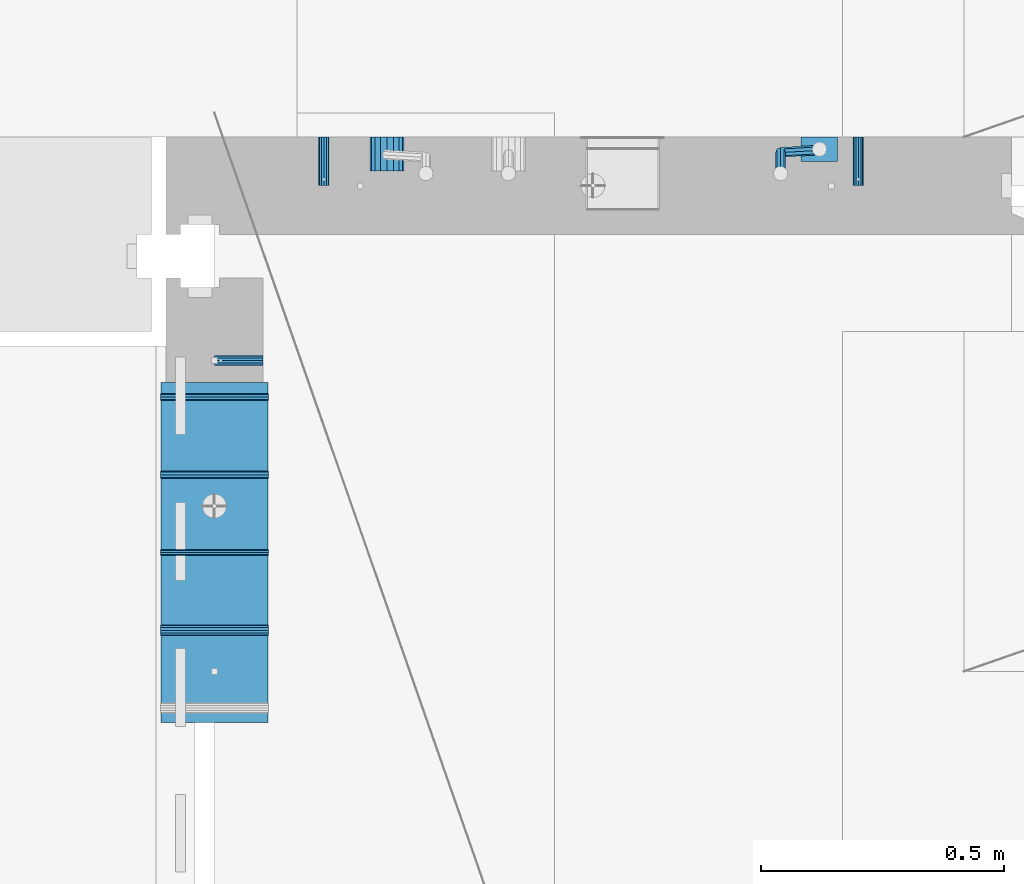
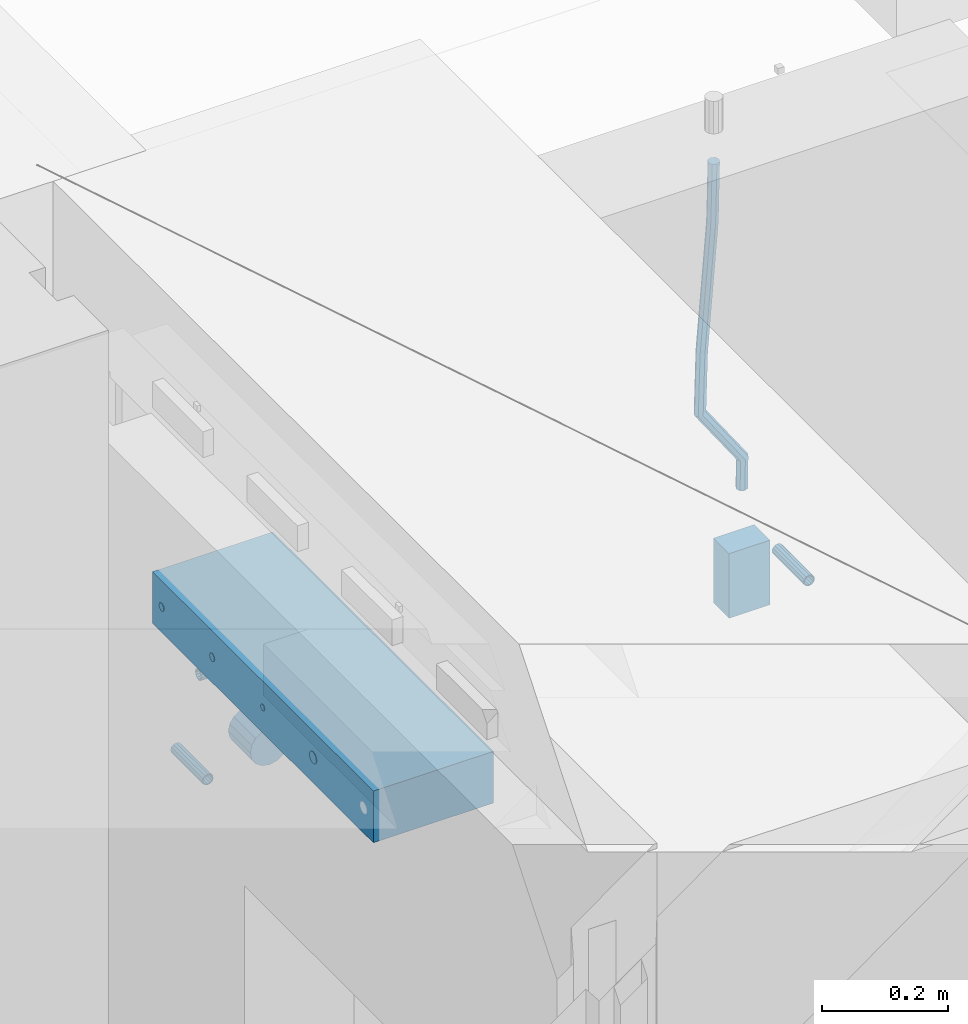
# One storey, part 164 of 349: 11 beams, 5 elements without a shape of their own.
"""IFC2X3 building model written with IfcOpenShell, lengths in millimetres."""

from ifc_helpers import new_model, si_unit, frame, origin_with_axes, place, context, subcontext, project, spatial, faceted_brep, material, type_object, element, aggregate, save


model = new_model("IFC2X3")

# Units and contexts
model_context = context("Model", 3, precision=1e-05, world=origin_with_axes())
body_context = subcontext(model_context, "Body", "Model", "MODEL_VIEW")
ifc_project = project(units=[si_unit("LENGTHUNIT", "METRE", prefix="MILLI"), si_unit("AREAUNIT", "SQUARE_METRE"), si_unit("VOLUMEUNIT", "CUBIC_METRE"), si_unit("MASSUNIT", "GRAM", prefix="KILO"), si_unit("TIMEUNIT", "SECOND"), si_unit("PLANEANGLEUNIT", "RADIAN"), si_unit("SOLIDANGLEUNIT", "STERADIAN"), si_unit("THERMODYNAMICTEMPERATUREUNIT", "DEGREE_CELSIUS"), si_unit("LUMINOUSINTENSITYUNIT", "LUMEN")], contexts=[model_context])

# Site, building, storey
site_placement = place(None, origin_with_axes())
site = spatial("IfcSite", under=ifc_project, at=site_placement, CompositionType="ELEMENT")
building_placement = place(site_placement, origin_with_axes())
building = spatial("IfcBuilding", under=site, at=building_placement, CompositionType="ELEMENT")
storey_placement = place(building_placement, origin_with_axes())
storey = spatial("IfcBuildingStorey", under=building, at=storey_placement, Name="4", CompositionType="ELEMENT", Elevation=0.0)

# Assemblies, beam
assembly_1_placement = place(storey_placement, origin_with_axes())
assembly_1 = element("IfcElementAssembly", 1, at=assembly_1_placement, inside=storey, AssemblyPlace="NOTDEFINED", PredefinedType="REINFORCEMENT_UNIT")
assembly_2_placement = place(assembly_1_placement, origin_with_axes())
assembly_2 = element("IfcElementAssembly", 2, at=assembly_2_placement, Name="Steel Assembly", AssemblyPlace="NOTDEFINED", PredefinedType="RIGID_FRAME")
ifc_material_1 = material(Name="STEEL/Steel_Undefined")
beam_type_1 = type_object("IfcBeamType", PredefinedType="NOTDEFINED")
beam_1_placement = place(assembly_2_placement, frame((26709.9991475894, 16620.0032612672, 93055.0), z_axis=(0.0, 1.0, 0.0), x_axis=(-1.0, 3.00000001838171e-08, 0.0)))
beam_1 = element("IfcBeam", 3, at=beam_1_placement, type_object=beam_type_1, material=ifc_material_1, Name="M16", context=body_context, shape_type="Brep", body=[
    faceted_brep([(0.0, -8.49999999999272, -1.45519152283669e-11), (0.0, -7.36121593215648, 4.24999999998545), (100.000000000262, -7.36121593215648, 4.24999999998545), (100.000000000262, -8.49999999999272, -1.45519152283669e-11), (0.0, -4.24999999998545, 7.36121593216376), (100.000000000262, -4.24999999998545, 7.36121593216376), (0.0, 1.45519152283669e-11, 8.49999999998545), (100.000000000262, 1.45519152283669e-11, 8.49999999998545), (0.0, 4.25000000001455, 7.36121593216376), (100.000000000262, 4.25000000001455, 7.36121593216376), (0.0, 7.36121593217104, 4.24999999998545), (100.000000000262, 7.36121593217104, 4.24999999998545), (0.0, 8.50000000000728, 0.0), (100.000000000262, 8.50000000000728, 0.0), (0.0, 7.36121593217104, -4.25000000001455), (100.000000000262, 7.36121593217104, -4.25000000001455), (0.0, 4.25000000000728, -7.36121593219286), (100.000000000262, 4.25000000000728, -7.36121593219286), (0.0, 7.27595761418343e-12, -8.5), (100.000000000262, 7.27595761418343e-12, -8.5), (0.0, -4.24999999999272, -7.36121593217831), (100.000000000262, -4.24999999999272, -7.36121593217831), (0.0, -7.36121593215648, -4.25), (100.000000000262, -7.36121593215648, -4.25), (0.0, -10.4999999999927, -1.45519152283669e-11), (0.0, -9.09326673972828, -5.25000000001455), (100.000000000262, -9.09326673972828, -5.25000000001455), (100.000000000262, -10.4999999999927, -1.45519152283669e-11), (0.0, -5.24999999998545, -9.09326673974283), (100.000000000262, -5.24999999998545, -9.09326673974283), (0.0, 7.27595761418343e-12, -10.5), (100.000000000262, 7.27595761418343e-12, -10.5), (0.0, 5.25000000001455, -9.09326673975738), (100.000000000262, 5.25000000001455, -9.09326673975738), (0.0, 9.09326673975011, -5.25000000001455), (100.000000000262, 9.09326673975011, -5.25000000001455), (0.0, 10.5000000000073, -1.45519152283669e-11), (100.000000000262, 10.5000000000073, -1.45519152283669e-11), (0.0, 9.09326673975011, 5.25), (100.000000000262, 9.09326673975011, 5.25), (0.0, 5.25000000000728, 9.09326673972828), (100.000000000262, 5.25000000000728, 9.09326673972828), (0.0, 1.45519152283669e-11, 10.4999999999854), (100.000000000262, 1.45519152283669e-11, 10.4999999999854), (0.0, -5.24999999999272, 9.09326673972828), (100.000000000262, -5.24999999999272, 9.09326673972828), (0.0, -9.09326673972828, 5.24999999998545), (100.000000000262, -9.09326673972828, 5.24999999998545)], [[[0, 1, 2, 3]], [[1, 4, 5, 2]], [[4, 6, 7, 5]], [[6, 8, 9, 7]], [[8, 10, 11, 9]], [[10, 12, 13, 11]], [[12, 14, 15, 13]], [[14, 16, 17, 15]], [[16, 18, 19, 17]], [[18, 20, 21, 19]], [[20, 22, 23, 21]], [[22, 0, 3, 23]], [[24, 25, 26, 27]], [[25, 28, 29, 26]], [[28, 30, 31, 29]], [[30, 32, 33, 31]], [[32, 34, 35, 33]], [[34, 36, 37, 35]], [[36, 38, 39, 37]], [[38, 40, 41, 39]], [[40, 42, 43, 41]], [[42, 44, 45, 43]], [[44, 46, 47, 45]], [[46, 24, 27, 47]], [[29, 31, 33, 35, 37, 39, 41, 43, 45, 47, 27, 26], [5, 7, 9, 11, 13, 15, 17, 19, 21, 23, 3, 2]], [[46, 44, 42, 40, 38, 36, 34, 32, 30, 28, 25, 24], [22, 20, 18, 16, 14, 12, 10, 8, 6, 4, 1, 0]]]),
])
aggregate(assembly_2, [beam_1])

# Assemblies, beams
assembly_3_placement = place(storey_placement, origin_with_axes())
assembly_3 = element("IfcElementAssembly", 4, at=assembly_3_placement, inside=storey, AssemblyPlace="NOTDEFINED", PredefinedType="REINFORCEMENT_UNIT")
assembly_4_placement = place(assembly_3_placement, origin_with_axes())
assembly_4 = element("IfcElementAssembly", 5, at=assembly_4_placement, Name="Steel Assembly", AssemblyPlace="NOTDEFINED", PredefinedType="RIGID_FRAME")
beam_2_placement = place(assembly_4_placement, frame((27934.9999668009, 17080.0, 92555.0), z_axis=(1.0, 0.0, 0.0), x_axis=(0.0, -1.0, 0.0)))
beam_2 = element("IfcBeam", 6, at=beam_2_placement, type_object=beam_type_1, material=ifc_material_1, Name="M16", context=body_context, shape_type="Brep", body=[
    faceted_brep([(0.0, -8.49999999999272, -1.45519152283669e-11), (0.0, -7.36121593215648, 4.24999999998545), (100.000000000262, -7.36121593215648, 4.24999999998545), (100.000000000262, -8.49999999999272, -1.45519152283669e-11), (0.0, -4.24999999998545, 7.36121593216376), (100.000000000262, -4.24999999998545, 7.36121593216376), (0.0, 1.45519152283669e-11, 8.49999999998545), (100.000000000262, 1.45519152283669e-11, 8.49999999998545), (0.0, 4.25000000001455, 7.36121593216376), (100.000000000262, 4.25000000001455, 7.36121593216376), (0.0, 7.36121593217104, 4.24999999998545), (100.000000000262, 7.36121593217104, 4.24999999998545), (0.0, 8.50000000000728, 0.0), (100.000000000262, 8.50000000000728, 0.0), (0.0, 7.36121593217104, -4.25000000001455), (100.000000000262, 7.36121593217104, -4.25000000001455), (0.0, 4.25000000000728, -7.36121593219286), (100.000000000262, 4.25000000000728, -7.36121593219286), (0.0, 7.27595761418343e-12, -8.5), (100.000000000262, 7.27595761418343e-12, -8.5), (0.0, -4.24999999999272, -7.36121593217831), (100.000000000262, -4.24999999999272, -7.36121593217831), (0.0, -7.36121593215648, -4.25), (100.000000000262, -7.36121593215648, -4.25), (0.0, -10.4999999999927, -1.45519152283669e-11), (0.0, -9.09326673972828, -5.25000000001455), (100.000000000262, -9.09326673972828, -5.25000000001455), (100.000000000262, -10.4999999999927, -1.45519152283669e-11), (0.0, -5.24999999998545, -9.09326673974283), (100.000000000262, -5.24999999998545, -9.09326673974283), (0.0, 7.27595761418343e-12, -10.5), (100.000000000262, 7.27595761418343e-12, -10.5), (0.0, 5.25000000001455, -9.09326673975738), (100.000000000262, 5.25000000001455, -9.09326673975738), (0.0, 9.09326673975011, -5.25000000001455), (100.000000000262, 9.09326673975011, -5.25000000001455), (0.0, 10.5000000000073, -1.45519152283669e-11), (100.000000000262, 10.5000000000073, -1.45519152283669e-11), (0.0, 9.09326673975011, 5.25), (100.000000000262, 9.09326673975011, 5.25), (0.0, 5.25000000000728, 9.09326673972828), (100.000000000262, 5.25000000000728, 9.09326673972828), (0.0, 1.45519152283669e-11, 10.4999999999854), (100.000000000262, 1.45519152283669e-11, 10.4999999999854), (0.0, -5.24999999999272, 9.09326673972828), (100.000000000262, -5.24999999999272, 9.09326673972828), (0.0, -9.09326673972828, 5.24999999998545), (100.000000000262, -9.09326673972828, 5.24999999998545)], [[[0, 1, 2, 3]], [[1, 4, 5, 2]], [[4, 6, 7, 5]], [[6, 8, 9, 7]], [[8, 10, 11, 9]], [[10, 12, 13, 11]], [[12, 14, 15, 13]], [[14, 16, 17, 15]], [[16, 18, 19, 17]], [[18, 20, 21, 19]], [[20, 22, 23, 21]], [[22, 0, 3, 23]], [[24, 25, 26, 27]], [[25, 28, 29, 26]], [[28, 30, 31, 29]], [[30, 32, 33, 31]], [[32, 34, 35, 33]], [[34, 36, 37, 35]], [[36, 38, 39, 37]], [[38, 40, 41, 39]], [[40, 42, 43, 41]], [[42, 44, 45, 43]], [[44, 46, 47, 45]], [[46, 24, 27, 47]], [[29, 31, 33, 35, 37, 39, 41, 43, 45, 47, 27, 26], [5, 7, 9, 11, 13, 15, 17, 19, 21, 23, 3, 2]], [[46, 44, 42, 40, 38, 36, 34, 32, 30, 28, 25, 24], [22, 20, 18, 16, 14, 12, 10, 8, 6, 4, 1, 0]]]),
])
aggregate(assembly_4, [beam_2])
assembly_5_placement = place(assembly_3_placement, origin_with_axes())
assembly_5 = element("IfcElementAssembly", 7, at=assembly_5_placement, Name="Steel Assembly", AssemblyPlace="NOTDEFINED", PredefinedType="RIGID_FRAME")
beam_3_placement = place(assembly_5_placement, frame((26834.9999668009, 17080.0, 92555.0), z_axis=(-1.0, 3.00000001838171e-08, 0.0), x_axis=(0.0, -1.0, 0.0)))
beam_3 = element("IfcBeam", 8, at=beam_3_placement, type_object=beam_type_1, material=ifc_material_1, Name="M16", context=body_context, shape_type="Brep", body=[
    faceted_brep([(0.0, -8.49999999999272, -1.45519152283669e-11), (0.0, -7.36121593215648, 4.24999999998545), (100.000000000262, -7.36121593215648, 4.24999999998545), (100.000000000262, -8.49999999999272, -1.45519152283669e-11), (0.0, -4.24999999998545, 7.36121593216376), (100.000000000262, -4.24999999998545, 7.36121593216376), (0.0, 1.45519152283669e-11, 8.49999999998545), (100.000000000262, 1.45519152283669e-11, 8.49999999998545), (0.0, 4.25000000001455, 7.36121593216376), (100.000000000262, 4.25000000001455, 7.36121593216376), (0.0, 7.36121593217104, 4.24999999998545), (100.000000000262, 7.36121593217104, 4.24999999998545), (0.0, 8.50000000000728, 0.0), (100.000000000262, 8.50000000000728, 0.0), (0.0, 7.36121593217104, -4.25000000001455), (100.000000000262, 7.36121593217104, -4.25000000001455), (0.0, 4.25000000000728, -7.36121593219286), (100.000000000262, 4.25000000000728, -7.36121593219286), (0.0, 7.27595761418343e-12, -8.5), (100.000000000262, 7.27595761418343e-12, -8.5), (0.0, -4.24999999999272, -7.36121593217831), (100.000000000262, -4.24999999999272, -7.36121593217831), (0.0, -7.36121593215648, -4.25), (100.000000000262, -7.36121593215648, -4.25), (0.0, -10.4999999999927, -1.45519152283669e-11), (0.0, -9.09326673972828, -5.25000000001455), (100.000000000262, -9.09326673972828, -5.25000000001455), (100.000000000262, -10.4999999999927, -1.45519152283669e-11), (0.0, -5.24999999998545, -9.09326673974283), (100.000000000262, -5.24999999998545, -9.09326673974283), (0.0, 7.27595761418343e-12, -10.5), (100.000000000262, 7.27595761418343e-12, -10.5), (0.0, 5.25000000001455, -9.09326673975738), (100.000000000262, 5.25000000001455, -9.09326673975738), (0.0, 9.09326673975011, -5.25000000001455), (100.000000000262, 9.09326673975011, -5.25000000001455), (0.0, 10.5000000000073, -1.45519152283669e-11), (100.000000000262, 10.5000000000073, -1.45519152283669e-11), (0.0, 9.09326673975011, 5.25), (100.000000000262, 9.09326673975011, 5.25), (0.0, 5.25000000000728, 9.09326673972828), (100.000000000262, 5.25000000000728, 9.09326673972828), (0.0, 1.45519152283669e-11, 10.4999999999854), (100.000000000262, 1.45519152283669e-11, 10.4999999999854), (0.0, -5.24999999999272, 9.09326673972828), (100.000000000262, -5.24999999999272, 9.09326673972828), (0.0, -9.09326673972828, 5.24999999998545), (100.000000000262, -9.09326673972828, 5.24999999998545)], [[[0, 1, 2, 3]], [[1, 4, 5, 2]], [[4, 6, 7, 5]], [[6, 8, 9, 7]], [[8, 10, 11, 9]], [[10, 12, 13, 11]], [[12, 14, 15, 13]], [[14, 16, 17, 15]], [[16, 18, 19, 17]], [[18, 20, 21, 19]], [[20, 22, 23, 21]], [[22, 0, 3, 23]], [[24, 25, 26, 27]], [[25, 28, 29, 26]], [[28, 30, 31, 29]], [[30, 32, 33, 31]], [[32, 34, 35, 33]], [[34, 36, 37, 35]], [[36, 38, 39, 37]], [[38, 40, 41, 39]], [[40, 42, 43, 41]], [[42, 44, 45, 43]], [[44, 46, 47, 45]], [[46, 24, 27, 47]], [[29, 31, 33, 35, 37, 39, 41, 43, 45, 47, 27, 26], [5, 7, 9, 11, 13, 15, 17, 19, 21, 23, 3, 2]], [[46, 44, 42, 40, 38, 36, 34, 32, 30, 28, 25, 24], [22, 20, 18, 16, 14, 12, 10, 8, 6, 4, 1, 0]]]),
])
aggregate(assembly_5, [beam_3])
ifc_material_2 = material()
beam_type_2 = type_object("IfcBeamType", Name="D20", PredefinedType="NOTDEFINED")
beam_4_placement = place(assembly_3_placement, frame((27854.9999105249, 17055.0000022791, 92717.5), z_axis=(0.00020576299992186, -0.999642804629538, -0.0267249099901004), x_axis=(-4.30000201928125e-08, -0.0267249099948059, 0.999642825806181)))
beam_4 = element("IfcBeam", 9, at=beam_4_placement, type_object=beam_type_2, material=ifc_material_2, Name="JM20", ObjectType="D20", context=body_context, shape_type="Brep", body=[
    faceted_brep([(0.0, -10.0, 0.0), (-4.19531716033816e-08, -7.07106781186667, -7.07106781187031), (57.3778003524785, -7.07106779628884, -7.0710678060168), (57.3778003565822, -9.99999998442945, 5.84986992180347e-09), (0.0, 0.0, -10.0), (57.3778003491898, 1.55741872731596e-08, -9.99999999415013), (4.196772351861e-08, 7.07106781186303, -7.07106781186667), (57.3778003486368, 7.07106782744086, -7.0710678060168), (0.0, 10.0, 0.0), (57.3778003511543, 10.0000000155705, 5.84986992180347e-09), (4.196772351861e-08, 7.07106781185939, 7.07106781185939), (57.3778003552725, 7.07106782744086, 7.0710678177129), (0.0, 0.0, 10.0), (57.3778003585467, 1.55741872731596e-08, 10.0000000058535), (-4.19531716033816e-08, -7.07106781187031, 7.07106781185939), (57.3778003591142, -7.07106779628884, 7.0710678177129), (63.2348501311644, -7.07106779493188, -7.07106780540926), (64.1057957623998, -9.99999998283238, 6.54472387395799e-09), (61.04994790192, 1.63490767590702e-08, -9.99999999377178), (58.8309751681372, 7.07106782761548, -7.07106780586037), (57.8777760627127, 10.0000000155014, 5.90807758271694e-09), (58.7487216939626, 7.07106782759729, 7.07106781786206), (60.9336239231925, 1.63163349498063e-08, 10.0000000062173), (63.1525966569752, -7.07106779495371, 7.07106781830953), (68.0560815638019, -3.74583294561307, -7.00896065082998), (69.6439432500047, -6.18030344188082, 0.0713424813729944), (64.0726841869619, 2.08480100043016, -9.96106107280502), (60.0271712784888, 7.89609210789058, -7.05565839484916), (58.2893494334276, 10.283864860914, 0.00530189843993867), (59.8772111196158, 7.84939436464629, 7.08560503063927), (63.8606084964704, 2.01876041860305, 10.037705452618), (67.9061214049289, -3.79253068885737, 7.13230277466573), (178.098456601496, 72.1511127806843, -5.59139360533663), (179.686318287684, 69.716642284413, 1.48890952685906), (174.115059224641, 77.9817467267239, -8.54349402731532), (170.069546316168, 83.7930378341844, -5.63809134935946), (168.331724471092, 86.1808105872078, 1.42286894392964), (169.91958615731, 83.7463400909437, 8.50317207612898), (173.90298353415, 77.9157061448968, 11.455272498104), (177.948496442623, 72.1044150374437, 8.5498698201518), (179.289255982527, 72.9724149014583, -5.57605371504542), (180.097891658399, 70.0005071298292, 1.4942114193982), (177.129995245661, 80.0611678177193, -8.50465558942597), (174.884975102759, 87.1142705605816, -5.5760589445199), (173.869297905752, 90.00011120009, 1.49420402380565), (174.67793358161, 87.0282034284573, 8.5644691582529), (176.837194318476, 79.9394505121963, 11.4930710326298), (179.082214461378, 72.8863477693376, 8.56447438772739), (180.735622590379, 72.972420835973, -5.54778204405011), (180.597796167538, 70.0005091809617, 1.50398289485383), (180.791991426609, 80.0611828430738, -8.4330757073476), (180.733882576489, 87.1142945589418, -5.46173219850607), (180.595335416292, 90.0001387973534, 1.62567575346111), (180.457508993451, 87.0282271423457, 8.67744069236505), (180.401140157206, 79.939465135245, 11.5627343556625), (180.459249007356, 72.8863534193733, 8.59139084682101), (299.223827734662, 72.9729069989553, -3.23173054285144), (299.086001311836, 70.0009953439476, 3.82003439605251), (299.280196570893, 80.0616690060597, -6.11702420615256), (299.222087720773, 87.1147807219277, -3.14568069731467), (299.083540560576, 90.0006249603393, 3.94172725465251), (298.945714137735, 87.0287133053316, 10.9934921935564), (298.889345301504, 79.9399512982272, 13.8787858568576), (298.947454151639, 72.8868395823556, 10.9074423480197), (300.386274806908, 72.9729117685347, -3.20900855728542), (299.975441269635, 70.0009989933678, 3.8374199978316), (300.554299891708, 80.0616742337661, -6.09211971118202), (300.381089708186, 87.1147854773699, -3.12302605173682), (299.968108432717, 90.0006285897653, 3.95901762330686), (299.557274895458, 87.0287158145948, 11.0054461784239), (299.389249810658, 79.9399533493597, 13.8885573323169), (299.562459994166, 72.8868421057559, 10.9194636728716), (301.54348499664, 72.972935138263, -3.09647384826167), (300.860874255726, 70.0010168745794, 3.92352530897551), (301.822663312996, 80.0616998482183, -5.96877573286474), (301.534870333402, 87.1148087778347, -3.01082485606094), (300.848691282124, 90.0006463730351, 4.04465127535514), (300.166080541225, 87.0287281093551, 11.0646504325923), (299.886902224855, 79.9399633993926, 13.9369523171918), (300.174695204449, 72.8868544697798, 10.9790014403879), (567.277632096637, 72.9783016087349, 22.7452575737989), (566.595021355723, 70.0063833450513, 29.7652567310361), (567.556810412992, 80.0670663186975, 19.8729556891958), (567.269017433413, 87.1201752483139, 22.8309065659996), (566.582838382135, 90.0060128435071, 29.886382697412), (565.900227641221, 87.0340945798234, 36.9063818546456), (565.621049324851, 79.9453298698681, 39.7786837392523), (565.90884230446, 72.8922209402554, 36.8207328624449), (567.849310941645, 72.9783131537188, 22.8008513743443), (567.441064932689, 70.0064004308078, 29.8475315576834), (568.054462827218, 80.0670763687303, 19.9213506740707), (567.93634539716, 87.1201887249226, 22.8958019142228), (567.564150240039, 90.0060326609891, 29.9818118989315), (567.155904231084, 87.0341199380709, 37.0284920822669), (566.950752345525, 79.9453567230667, 39.9079927825405), (567.068869775569, 72.8922443668707, 36.9335415423957), (568.423586898687, 72.9708243880268, 22.8084944200891), (568.290952048657, 69.9953175961527, 29.8588427157192), (568.554376054599, 80.0605573198627, 19.9280040253361), (568.606705002705, 87.1114469937784, 22.9047237384184), (568.549920154881, 89.9931778656028, 29.9949315228005), (568.417285304851, 87.0176710737251, 37.0452798184269), (568.286496148939, 79.9279381418964, 39.9257702131799), (568.234167200833, 72.8770484679771, 36.9490505000977), (589.912124239258, 72.6906061074042, 23.0944856267633), (589.779489389242, 69.7150993155265, 30.1448339223862), (590.042913395198, 79.7803390392328, 20.2139952320067), (590.095242343275, 86.8312287131521, 23.190714945089), (590.038457495451, 89.7129595849765, 30.2809227294711), (589.905822645451, 86.7374527930988, 37.3312710250975), (589.775033489525, 79.6477198612702, 40.2117614198505), (589.722704541418, 72.5968301873472, 37.2350417067682), (590.547165551296, 72.6823249395493, 23.1029373993588), (590.439554471668, 69.7064918286778, 30.1536187366546), (590.620682129796, 79.7728047264573, 20.2216847631717), (590.617039192599, 86.8244242939545, 23.197659545749), (590.538370722847, 89.7064405361089, 30.2875760807365), (590.430759643248, 86.7306074252338, 37.3382574180287), (590.357243064718, 79.6401276383258, 40.2195100542194), (590.36088600193, 72.5885080708285, 37.243535271642), (591.182260594243, 72.6841934809891, 23.1112002334121), (591.099675200006, 69.7084600799535, 30.1622167658497), (591.198500084778, 79.7744922147613, 20.2291794306657), (591.138880798317, 86.8259554442993, 23.2044030568104), (591.038326904265, 89.7079316443269, 30.2940254627501), (590.955741510043, 86.7321982432914, 37.3450419951805), (590.939502019522, 79.6418995095191, 40.2270627979342), (590.999121305984, 72.5904362799774, 37.2518391717822), (691.203058405095, 72.9824563748625, 24.4085746238379), (691.120473010888, 70.0067229738306, 31.4595911562756), (691.219297895645, 80.0727551086347, 21.5265538210951), (691.159678609169, 87.1242183381728, 24.5017774472362), (691.059124715146, 90.0061945381967, 31.591399853176), (690.976539320895, 87.0304611371721, 38.6424163856136), (690.960299830374, 79.9401624033926, 41.5244371883564), (691.019919116836, 72.8886991738545, 38.5492135622153)], [[[0, 1, 2, 3]], [[1, 4, 5, 2]], [[4, 6, 7, 5]], [[6, 8, 9, 7]], [[8, 10, 11, 9]], [[10, 12, 13, 11]], [[12, 14, 15, 13]], [[14, 0, 3, 15]], [[14, 12, 10, 8, 6, 4, 1, 0]], [[3, 2, 16, 17]], [[2, 5, 18, 16]], [[5, 7, 19, 18]], [[7, 9, 20, 19]], [[9, 11, 21, 20]], [[11, 13, 22, 21]], [[13, 15, 23, 22]], [[15, 3, 17, 23]], [[17, 16, 24, 25]], [[16, 18, 26, 24]], [[18, 19, 27, 26]], [[19, 20, 28, 27]], [[20, 21, 29, 28]], [[21, 22, 30, 29]], [[22, 23, 31, 30]], [[23, 17, 25, 31]], [[25, 24, 32, 33]], [[24, 26, 34, 32]], [[26, 27, 35, 34]], [[27, 28, 36, 35]], [[28, 29, 37, 36]], [[29, 30, 38, 37]], [[30, 31, 39, 38]], [[31, 25, 33, 39]], [[33, 32, 40, 41]], [[32, 34, 42, 40]], [[34, 35, 43, 42]], [[35, 36, 44, 43]], [[36, 37, 45, 44]], [[37, 38, 46, 45]], [[38, 39, 47, 46]], [[39, 33, 41, 47]], [[41, 40, 48, 49]], [[40, 42, 50, 48]], [[42, 43, 51, 50]], [[43, 44, 52, 51]], [[44, 45, 53, 52]], [[45, 46, 54, 53]], [[46, 47, 55, 54]], [[47, 41, 49, 55]], [[49, 48, 56, 57]], [[48, 50, 58, 56]], [[50, 51, 59, 58]], [[51, 52, 60, 59]], [[52, 53, 61, 60]], [[53, 54, 62, 61]], [[54, 55, 63, 62]], [[55, 49, 57, 63]], [[57, 56, 64, 65]], [[56, 58, 66, 64]], [[58, 59, 67, 66]], [[59, 60, 68, 67]], [[60, 61, 69, 68]], [[61, 62, 70, 69]], [[62, 63, 71, 70]], [[63, 57, 65, 71]], [[65, 64, 72, 73]], [[64, 66, 74, 72]], [[66, 67, 75, 74]], [[67, 68, 76, 75]], [[68, 69, 77, 76]], [[69, 70, 78, 77]], [[70, 71, 79, 78]], [[71, 65, 73, 79]], [[73, 72, 80, 81]], [[72, 74, 82, 80]], [[74, 75, 83, 82]], [[75, 76, 84, 83]], [[76, 77, 85, 84]], [[77, 78, 86, 85]], [[78, 79, 87, 86]], [[79, 73, 81, 87]], [[81, 80, 88, 89]], [[80, 82, 90, 88]], [[82, 83, 91, 90]], [[83, 84, 92, 91]], [[84, 85, 93, 92]], [[85, 86, 94, 93]], [[86, 87, 95, 94]], [[87, 81, 89, 95]], [[89, 88, 96, 97]], [[88, 90, 98, 96]], [[90, 91, 99, 98]], [[91, 92, 100, 99]], [[92, 93, 101, 100]], [[93, 94, 102, 101]], [[94, 95, 103, 102]], [[95, 89, 97, 103]], [[97, 96, 104, 105]], [[96, 98, 106, 104]], [[98, 99, 107, 106]], [[99, 100, 108, 107]], [[100, 101, 109, 108]], [[101, 102, 110, 109]], [[102, 103, 111, 110]], [[103, 97, 105, 111]], [[105, 104, 112, 113]], [[104, 106, 114, 112]], [[106, 107, 115, 114]], [[107, 108, 116, 115]], [[108, 109, 117, 116]], [[109, 110, 118, 117]], [[110, 111, 119, 118]], [[111, 105, 113, 119]], [[113, 112, 120, 121]], [[112, 114, 122, 120]], [[114, 115, 123, 122]], [[115, 116, 124, 123]], [[116, 117, 125, 124]], [[117, 118, 126, 125]], [[118, 119, 127, 126]], [[119, 113, 121, 127]], [[121, 120, 128, 129]], [[120, 122, 130, 128]], [[122, 123, 131, 130]], [[123, 124, 132, 131]], [[124, 125, 133, 132]], [[125, 126, 134, 133]], [[126, 127, 135, 134]], [[127, 121, 129, 135]], [[130, 131, 132, 133, 134, 135, 129, 128]]]),
])
beam_type_3 = type_object("IfcBeamType", Name="D70", PredefinedType="NOTDEFINED")
beam_5_placement = place(assembly_3_placement, frame((26964.9999105288, 17080.0000022791, 92555.0), z_axis=(0.0, 0.0, 1.0), x_axis=(0.0, -1.0, 0.0)))
beam_5 = element("IfcBeam", 10, at=beam_5_placement, type_object=beam_type_3, material=ifc_material_2, ObjectType="D70", context=body_context, shape_type="Brep", body=[
    faceted_brep([(0.0, -35.0, 0.0), (0.0, -32.3357836378964, -13.3939201327739), (70.0, -32.3357836378964, -13.3939201327739), (70.0, -35.0, 0.0), (0.0, -24.7487373415279, -24.7487373415352), (70.0, -24.7487373415279, -24.7487373415352), (0.0, -13.3939201327776, -32.3357836379), (70.0, -13.3939201327776, -32.3357836379), (0.0, 0.0, -35.0), (70.0, 0.0, -35.0), (0.0, 13.3939201327776, -32.3357836379), (70.0, 13.3939201327776, -32.3357836379), (0.0, 24.7487373415279, -24.7487373415352), (70.0, 24.7487373415279, -24.7487373415352), (0.0, 32.3357836378964, -13.3939201327739), (70.0, 32.3357836378964, -13.3939201327739), (0.0, 35.0, 0.0), (70.0, 35.0, 0.0), (0.0, 32.3357836378964, 13.3939201327739), (70.0, 32.3357836378964, 13.3939201327739), (0.0, 24.7487373415279, 24.7487373415352), (70.0, 24.7487373415279, 24.7487373415352), (0.0, 13.3939201327776, 32.3357836379), (70.0, 13.3939201327776, 32.3357836379), (0.0, 0.0, 35.0), (70.0, 0.0, 35.0), (0.0, -13.3939201327776, 32.3357836379), (70.0, -13.3939201327776, 32.3357836379), (0.0, -24.7487373415279, 24.7487373415352), (70.0, -24.7487373415279, 24.7487373415352), (0.0, -32.3357836378964, 13.3939201327739), (70.0, -32.3357836378964, 13.3939201327739)], [[[0, 1, 2, 3]], [[1, 4, 5, 2]], [[4, 6, 7, 5]], [[6, 8, 9, 7]], [[8, 10, 11, 9]], [[10, 12, 13, 11]], [[12, 14, 15, 13]], [[14, 16, 17, 15]], [[16, 18, 19, 17]], [[18, 20, 21, 19]], [[20, 22, 23, 21]], [[22, 24, 25, 23]], [[24, 26, 27, 25]], [[26, 28, 29, 27]], [[28, 30, 31, 29]], [[30, 0, 3, 31]], [[5, 7, 9, 11, 13, 15, 17, 19, 21, 23, 25, 27, 29, 31, 3, 2]], [[30, 28, 26, 24, 22, 20, 18, 16, 14, 12, 10, 8, 6, 4, 1, 0]]]),
])

# Beam
ifc_material_3 = material()
beam_type_4 = type_object("IfcBeamType", Name="D12", PredefinedType="NOTDEFINED")
beam_6_placement = place(assembly_1_placement, frame((26720.9994161083, 16225.0, 93270.0), z_axis=(0.0, -1.0, 0.0), x_axis=(-1.0, 3.00000001838171e-08, 0.0)))
beam_6 = element("IfcBeam", 11, at=beam_6_placement, type_object=beam_type_4, material=ifc_material_3, Name="12", ObjectType="D12", context=body_context, shape_type="Brep", body=[
    faceted_brep([(0.0, -6.0, -1.45519152283669e-11), (0.0, -4.24264068712, -4.24264068713819), (222.000077784061, -4.24264068712364, -4.24264068712), (222.000077784061, -6.0, 0.0), (3.63797880709171e-12, 0.0, -6.0000000000291), (222.000077784061, 0.0, -6.0), (0.0, 4.24264068712, -4.24264068713819), (222.000077784061, 4.24264068712364, -4.24264068712), (0.0, 6.0, -1.45519152283669e-11), (222.000077784061, 6.0, 0.0), (0.0, 4.24264068712, 4.24264068709454), (222.000077784061, 4.24264068712364, 4.24264068712), (0.0, 0.0, 5.99999999998545), (222.000077784061, 0.0, 6.0), (0.0, -4.24264068712, 4.24264068709454), (222.000077784061, -4.24264068712364, 4.24264068712)], [[[0, 1, 2, 3]], [[1, 4, 5, 2]], [[4, 6, 7, 5]], [[6, 8, 9, 7]], [[8, 10, 11, 9]], [[10, 12, 13, 11]], [[12, 14, 15, 13]], [[14, 0, 3, 15]], [[5, 7, 9, 11, 13, 15, 3, 2]], [[14, 12, 10, 8, 6, 4, 1, 0]]]),
])

beam_type_5 = type_object("IfcBeamType", Name="D15", PredefinedType="NOTDEFINED")
beam_7_placement = place(assembly_1_placement, frame((26720.9994161083, 16544.9998474121, 93270.0), z_axis=(0.0, -1.0, 0.0), x_axis=(-1.0, 3.00000001838171e-08, 0.0)))
beam_7 = element("IfcBeam", 12, at=beam_7_placement, type_object=beam_type_5, material=ifc_material_3, Name="15", ObjectType="D15", context=body_context, shape_type="Brep", body=[
    faceted_brep([(0.0, -7.5, 0.0), (0.0, -5.30330085889727, -5.30330085890091), (222.000077784061, -5.30330085889727, -5.30330085890091), (222.000077784061, -7.5, 0.0), (0.0, 1.45519152283669e-11, -7.5), (222.000077784061, 0.0, -7.5), (0.0, 5.30330085889727, -5.30330085890091), (222.000077784061, 5.30330085889727, -5.30330085890091), (0.0, 7.5, 0.0), (222.000077784061, 7.5, 0.0), (0.0, 5.30330085889727, 5.30330085890091), (222.000077784061, 5.30330085889727, 5.30330085890091), (0.0, 1.45519152283669e-11, 7.5), (222.000077784061, 0.0, 7.5), (0.0, -5.30330085889727, 5.30330085890091), (222.000077784061, -5.30330085889727, 5.30330085890091)], [[[0, 1, 2, 3]], [[1, 4, 5, 2]], [[4, 6, 7, 5]], [[6, 8, 9, 7]], [[8, 10, 11, 9]], [[10, 12, 13, 11]], [[12, 14, 15, 13]], [[14, 0, 3, 15]], [[5, 7, 9, 11, 13, 15, 3, 2]], [[14, 12, 10, 8, 6, 4, 1, 0]]]),
])

beam_8_placement = place(assembly_1_placement, frame((26720.9994161083, 16385.0, 93270.0), z_axis=(0.0, -1.0, 0.0), x_axis=(-1.0, 3.00000001838171e-08, 0.0)))
beam_8 = element("IfcBeam", 13, at=beam_8_placement, type_object=beam_type_5, material=ifc_material_3, Name="15", ObjectType="D15", context=body_context, shape_type="Brep", body=[
    faceted_brep([(0.0, -7.5, 0.0), (0.0, -5.30330085889727, -5.30330085890091), (222.000077784061, -5.30330085889727, -5.30330085890091), (222.000077784061, -7.5, 0.0), (0.0, 1.45519152283669e-11, -7.5), (222.000077784061, 0.0, -7.5), (0.0, 5.30330085889727, -5.30330085890091), (222.000077784061, 5.30330085889727, -5.30330085890091), (0.0, 7.5, 0.0), (222.000077784061, 7.5, 0.0), (0.0, 5.30330085889727, 5.30330085890091), (222.000077784061, 5.30330085889727, 5.30330085890091), (0.0, 1.45519152283669e-11, 7.5), (222.000077784061, 0.0, 7.5), (0.0, -5.30330085889727, 5.30330085890091), (222.000077784061, -5.30330085889727, 5.30330085890091)], [[[0, 1, 2, 3]], [[1, 4, 5, 2]], [[4, 6, 7, 5]], [[6, 8, 9, 7]], [[8, 10, 11, 9]], [[10, 12, 13, 11]], [[12, 14, 15, 13]], [[14, 0, 3, 15]], [[5, 7, 9, 11, 13, 15, 3, 2]], [[14, 12, 10, 8, 6, 4, 1, 0]]]),
])

beam_type_6 = type_object("IfcBeamType", Name="D22", PredefinedType="NOTDEFINED")
beam_9_placement = place(assembly_1_placement, frame((26720.9994161083, 16065.0, 93270.0), z_axis=(0.0, -1.0, 0.0), x_axis=(-1.0, 3.00000001838171e-08, 0.0)))
beam_9 = element("IfcBeam", 14, at=beam_9_placement, type_object=beam_type_6, material=ifc_material_3, Name="22", ObjectType="D22", context=body_context, shape_type="Brep", body=[
    faceted_brep([(0.0, -11.0, 0.0), (0.0, -9.52627944163396, -5.5), (222.000077784061, -9.52627944163396, -5.5), (222.000077784061, -11.0, 0.0), (0.0, -5.5, -9.52627944163032), (222.000077784061, -5.5, -9.52627944163032), (0.0, 0.0, -11.0), (222.000077784061, 0.0, -11.0), (0.0, 5.5, -9.52627944163032), (222.000077784061, 5.5, -9.52627944163032), (0.0, 9.52627944163396, -5.5), (222.000077784061, 9.52627944163396, -5.5), (0.0, 11.0, 0.0), (222.000077784061, 11.0, 0.0), (0.0, 9.52627944163396, 5.5), (222.000077784061, 9.52627944163396, 5.5), (0.0, 5.5, 9.52627944163032), (222.000077784061, 5.5, 9.52627944163032), (0.0, 0.0, 11.0), (222.000077784061, 0.0, 11.0), (0.0, -5.5, 9.52627944163032), (222.000077784061, -5.5, 9.52627944163032), (0.0, -9.52627944163396, 5.5), (222.000077784061, -9.52627944163396, 5.5)], [[[0, 1, 2, 3]], [[1, 4, 5, 2]], [[4, 6, 7, 5]], [[6, 8, 9, 7]], [[8, 10, 11, 9]], [[10, 12, 13, 11]], [[12, 14, 15, 13]], [[14, 16, 17, 15]], [[16, 18, 19, 17]], [[18, 20, 21, 19]], [[20, 22, 23, 21]], [[22, 0, 3, 23]], [[5, 7, 9, 11, 13, 15, 17, 19, 21, 23, 3, 2]], [[22, 20, 18, 16, 14, 12, 10, 8, 6, 4, 1, 0]]]),
])

beam_type_7 = type_object("IfcBeamType", PredefinedType="NOTDEFINED")
beam_10_placement = place(assembly_1_placement, frame((26719.9994161083, 16225.0, 93270.0), z_axis=(0.0, -1.0, 0.0), x_axis=(-1.0, 3.00000001838171e-08, 0.0)))
beam_10 = element("IfcBeam", 15, at=beam_10_placement, type_object=beam_type_7, material=ifc_material_3, context=body_context, shape_type="Brep", body=[
    faceted_brep([(0.0, 50.0, -350.0), (0.0, 50.0, 350.0), (220.000077784061, 50.0, 350.0), (220.000077784061, 50.0, -350.0), (0.0, -50.0, 350.0), (220.000077784061, -50.0, 350.0), (0.0, -50.0, -350.0), (220.000077784061, -50.0, -350.0)], [[[0, 1, 2, 3]], [[1, 4, 5, 2]], [[4, 6, 7, 5]], [[6, 0, 3, 7]], [[5, 7, 3, 2]], [[6, 4, 1, 0]]]),
])

aggregate(assembly_1, [assembly_2, beam_9, beam_6, beam_10, beam_7, beam_8])

beam_type_8 = type_object("IfcBeamType", PredefinedType="NOTDEFINED")
beam_11_placement = place(assembly_3_placement, frame((27892.4999105288, 17055.0, 92555.0), z_axis=(0.0, 0.0, 1.0), x_axis=(-1.0, 3.00000001838171e-08, 0.0)))
beam_11 = element("IfcBeam", 16, at=beam_11_placement, type_object=beam_type_8, material=ifc_material_2, Name="WM1", context=body_context, shape_type="Brep", body=[
    faceted_brep([(0.0, 25.0, -62.5), (0.0, 25.0, 62.5), (75.0, 25.0, 62.5), (75.0, 25.0, -62.5), (0.0, -25.0, 62.5), (75.0, -25.0, 62.5), (0.0, -25.0, -62.5), (75.0, -25.0, -62.5)], [[[0, 1, 2, 3]], [[1, 4, 5, 2]], [[4, 6, 7, 5]], [[6, 0, 3, 7]], [[5, 7, 3, 2]], [[0, 6, 4, 1]]]),
])

aggregate(assembly_3, [assembly_4, assembly_5, beam_4, beam_11, beam_5])

save(model, "model.ifc")
